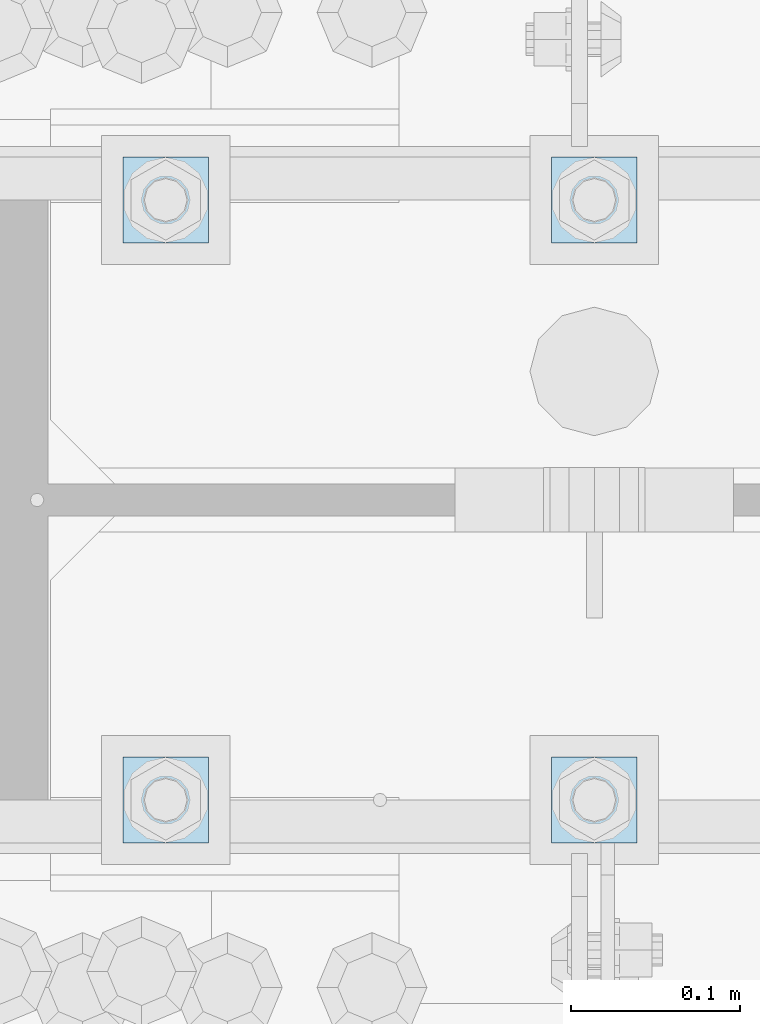
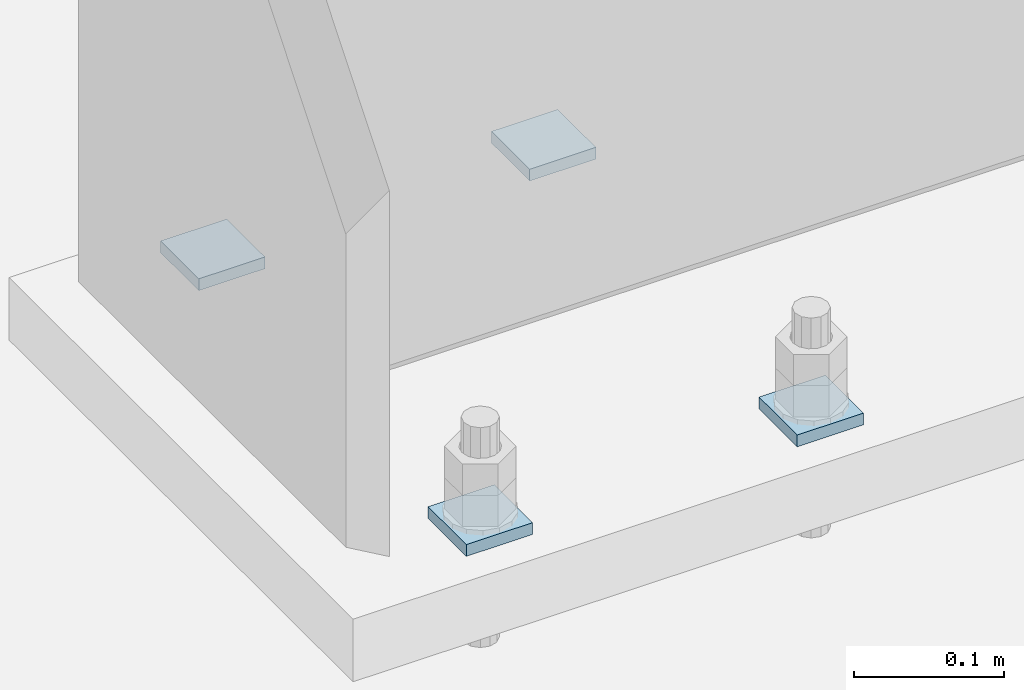
# One storey, part 1713 of 1763: 4 plates, 1 element without a shape of its own.
"""IFC2X3 building model written with IfcOpenShell, lengths in millimetres."""

from ifc_helpers import new_model, si_unit, frame, origin_with_axes, place, context, subcontext, project, spatial, faceted_brep, material, type_object, element, aggregate, save


model = new_model("IFC2X3")

# Units and contexts
model_context = context("Model", 3, precision=1e-05, world=origin_with_axes())
body_context = subcontext(model_context, "Body", "Model", "MODEL_VIEW")
ifc_project = project(units=[si_unit("LENGTHUNIT", "METRE", prefix="MILLI"), si_unit("AREAUNIT", "SQUARE_METRE"), si_unit("VOLUMEUNIT", "CUBIC_METRE"), si_unit("MASSUNIT", "GRAM", prefix="KILO"), si_unit("TIMEUNIT", "SECOND"), si_unit("PLANEANGLEUNIT", "RADIAN"), si_unit("SOLIDANGLEUNIT", "STERADIAN"), si_unit("THERMODYNAMICTEMPERATUREUNIT", "DEGREE_CELSIUS"), si_unit("LUMINOUSINTENSITYUNIT", "LUMEN")], contexts=[model_context])

# Site, building, storey
site_placement = place(None, origin_with_axes())
site = spatial("IfcSite", under=ifc_project, at=site_placement, CompositionType="ELEMENT")
building_placement = place(site_placement, origin_with_axes())
building = spatial("IfcBuilding", under=site, at=building_placement, Name="Undefined", CompositionType="ELEMENT")
storey_placement = place(building_placement, origin_with_axes())
storey = spatial("IfcBuildingStorey", under=building, at=storey_placement, Name="Undefined", CompositionType="ELEMENT", Elevation=0.0)

# Assembly, plates
assembly_placement = place(storey_placement, origin_with_axes())
assembly = element("IfcElementAssembly", 1, at=assembly_placement, inside=storey, Name="TEMPLATE", AssemblyPlace="NOTDEFINED", PredefinedType="RIGID_FRAME")
ifc_material = material(Name="STEEL/A36")
plate_type = type_object("IfcPlateType", PredefinedType="NOTDEFINED")
plate_1_placement = place(assembly_placement, frame((-49427.8372736984, 51968.4, -211.137499999999), z_axis=(0.0, -1.0, 0.0), x_axis=(1.0, 0.0, 0.0)))
plate_1 = element("IfcPlate", 2, at=plate_1_placement, type_object=plate_type, material=ifc_material, Name="Washer Plate", context=body_context, shape_type="Brep", body=[
    faceted_brep([(0.0, -4.76249999999982, 0.0), (0.0, -4.76249999999999, 50.7999992370605), (0.0, 4.76249999999999, 50.7999992370605), (0.0, 4.76249999999982, 0.0), (50.7999992370605, -4.76249999999999, 50.7999992370605), (50.7999992370605, 4.76249999999999, 50.7999992370605), (50.7999992370605, -4.76249999999709, 0.0), (50.7999992370605, 4.76249999999709, 0.0)], [[[0, 1, 2, 3]], [[1, 4, 5, 2]], [[4, 6, 7, 5]], [[6, 0, 3, 7]], [[5, 7, 3, 2]], [[6, 4, 1, 0]]]),
])
plate_2_placement = place(assembly_placement, frame((-49427.8372736984, 52324.0, -211.137499999999), z_axis=(0.0, -1.0, 0.0), x_axis=(1.0, 0.0, 0.0)))
plate_2 = element("IfcPlate", 3, at=plate_2_placement, type_object=plate_type, material=ifc_material, Name="Washer Plate", context=body_context, shape_type="Brep", body=[
    faceted_brep([(0.0, -4.76249999999982, 0.0), (0.0, -4.76249999999999, 50.7999992370605), (0.0, 4.76249999999999, 50.7999992370605), (0.0, 4.76249999999982, 0.0), (50.7999992370605, -4.76249999999999, 50.7999992370605), (50.7999992370605, 4.76249999999999, 50.7999992370605), (50.7999992370605, -4.76249999999709, 0.0), (50.7999992370605, 4.76249999999709, 0.0)], [[[0, 1, 2, 3]], [[1, 4, 5, 2]], [[4, 6, 7, 5]], [[6, 0, 3, 7]], [[5, 7, 3, 2]], [[6, 4, 1, 0]]]),
])
plate_3_placement = place(assembly_placement, frame((-49681.8372736984, 51968.4, -211.137499999999), z_axis=(0.0, -1.0, 0.0), x_axis=(1.0, 0.0, 0.0)))
plate_3 = element("IfcPlate", 4, at=plate_3_placement, type_object=plate_type, material=ifc_material, Name="Washer Plate", context=body_context, shape_type="Brep", body=[
    faceted_brep([(0.0, -4.76249999999982, 0.0), (0.0, -4.76249999999999, 50.7999992370605), (0.0, 4.76249999999999, 50.7999992370605), (0.0, 4.76249999999982, 0.0), (50.7999992370605, -4.76249999999999, 50.7999992370605), (50.7999992370605, 4.76249999999999, 50.7999992370605), (50.7999992370605, -4.76249999999709, 0.0), (50.7999992370605, 4.76249999999709, 0.0)], [[[0, 1, 2, 3]], [[1, 4, 5, 2]], [[4, 6, 7, 5]], [[6, 0, 3, 7]], [[5, 7, 3, 2]], [[6, 4, 1, 0]]]),
])
plate_4_placement = place(assembly_placement, frame((-49681.8372736984, 52324.0, -211.137499999999), z_axis=(0.0, -1.0, 0.0), x_axis=(1.0, 0.0, 0.0)))
plate_4 = element("IfcPlate", 5, at=plate_4_placement, type_object=plate_type, material=ifc_material, Name="Washer Plate", context=body_context, shape_type="Brep", body=[
    faceted_brep([(0.0, -4.76249999999982, 0.0), (0.0, -4.76249999999999, 50.7999992370605), (0.0, 4.76249999999999, 50.7999992370605), (0.0, 4.76249999999982, 0.0), (50.7999992370605, -4.76249999999999, 50.7999992370605), (50.7999992370605, 4.76249999999999, 50.7999992370605), (50.7999992370605, -4.76249999999709, 0.0), (50.7999992370605, 4.76249999999709, 0.0)], [[[0, 1, 2, 3]], [[1, 4, 5, 2]], [[4, 6, 7, 5]], [[6, 0, 3, 7]], [[5, 7, 3, 2]], [[6, 4, 1, 0]]]),
])
aggregate(assembly, [plate_1, plate_2, plate_3, plate_4])

save(model, "model.ifc")
